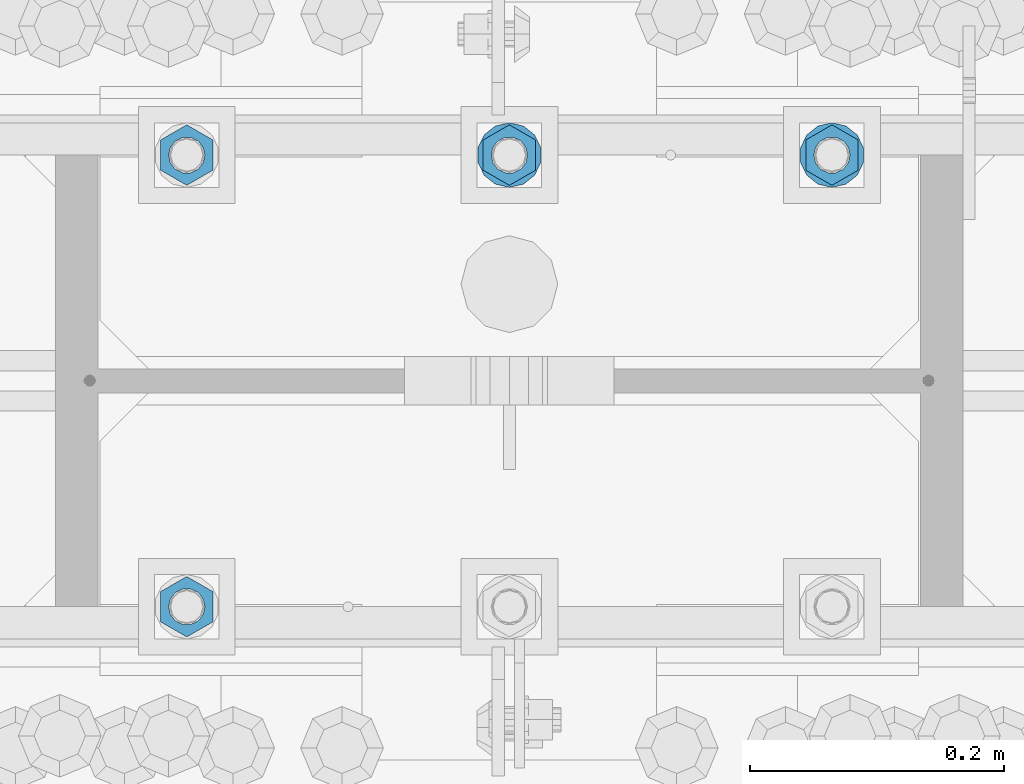
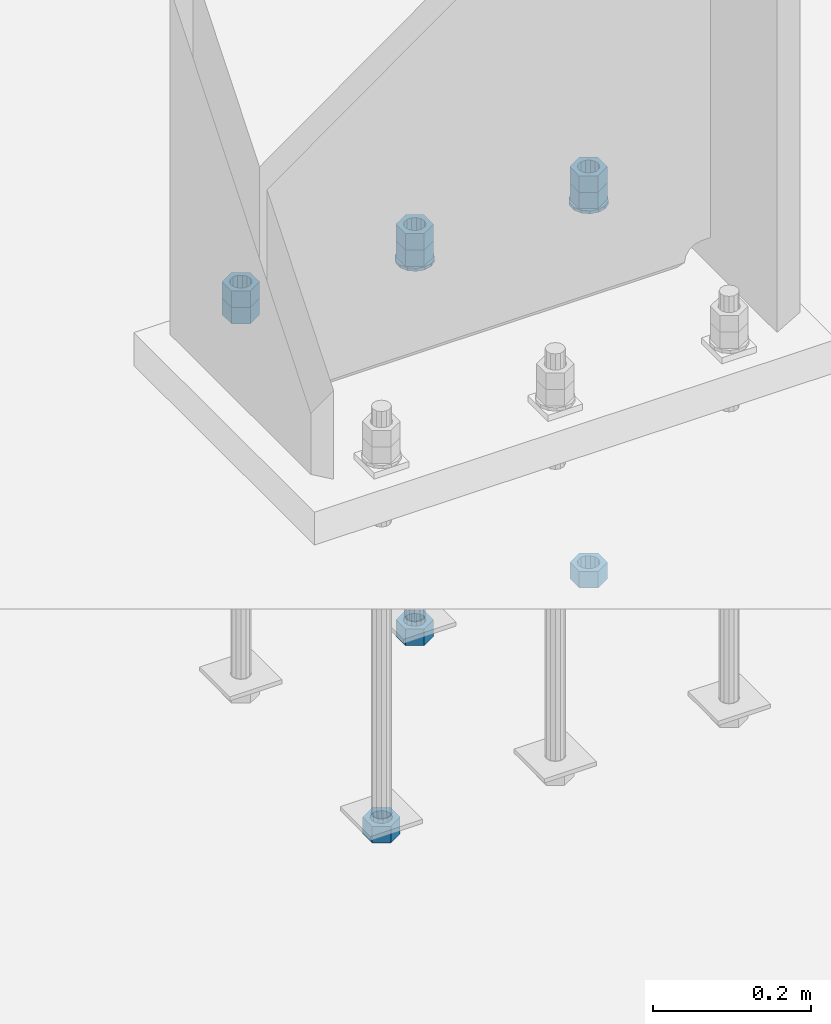
# One storey, part 1020 of 1763: 11 columns, 1 element without a shape of its own.
"""IFC2X3 building model written with IfcOpenShell, lengths in millimetres."""

from ifc_helpers import new_model, si_unit, frame, origin_with_axes, place, context, subcontext, project, spatial, faceted_brep, material, type_object, element, aggregate, save


model = new_model("IFC2X3")

# Units and contexts
model_context = context("Model", 3, precision=1e-05, world=origin_with_axes())
body_context = subcontext(model_context, "Body", "Model", "MODEL_VIEW")
ifc_project = project(units=[si_unit("LENGTHUNIT", "METRE", prefix="MILLI"), si_unit("AREAUNIT", "SQUARE_METRE"), si_unit("VOLUMEUNIT", "CUBIC_METRE"), si_unit("MASSUNIT", "GRAM", prefix="KILO"), si_unit("TIMEUNIT", "SECOND"), si_unit("PLANEANGLEUNIT", "RADIAN"), si_unit("SOLIDANGLEUNIT", "STERADIAN"), si_unit("THERMODYNAMICTEMPERATUREUNIT", "DEGREE_CELSIUS"), si_unit("LUMINOUSINTENSITYUNIT", "LUMEN")], contexts=[model_context])

# Site, building, storey
site_placement = place(None, origin_with_axes())
site = spatial("IfcSite", under=ifc_project, at=site_placement, CompositionType="ELEMENT")
building_placement = place(site_placement, origin_with_axes())
building = spatial("IfcBuilding", under=site, at=building_placement, Name="Undefined", CompositionType="ELEMENT")
storey_placement = place(building_placement, origin_with_axes())
storey = spatial("IfcBuildingStorey", under=building, at=storey_placement, Name="Undefined", CompositionType="ELEMENT", Elevation=0.0)

# Assembly, columns
assembly_placement = place(storey_placement, origin_with_axes())
assembly = element("IfcElementAssembly", 1, at=assembly_placement, inside=storey, Name="TEMPLATE", AssemblyPlace="NOTDEFINED", PredefinedType="RIGID_FRAME")
ifc_material_1 = material(Name="STEEL/A563")
column_type_1 = type_object("IfcColumnType", Name="1_HEAVY_HEX_NUT", PredefinedType="NOTDEFINED")
column_1_placement = place(assembly_placement, frame((-72237.0372736984, 52298.6, -150.812499999999), z_axis=(-1.0, 0.0, 0.0), x_axis=(0.0, 0.0, -1.0)))
column_1 = element("IfcColumn", 2, at=column_1_placement, type_object=column_type_1, material=ifc_material_1, Name="NUT", ObjectType="1_HEAVY_HEX_NUT", context=body_context, shape_type="Brep", body=[
    faceted_brep([(0.0, -23.8099994659424, 0.0), (0.0, -11.9099998474121, -20.6200008392334), (25.4, -11.9099998474121, -20.6200008392334), (25.4, -23.8099994659424, 0.0), (0.0, 11.9099998474121, -20.6200008392334), (25.4, 11.9099998474121, -20.6200008392334), (0.0, 23.8099994659424, 0.0), (25.4, 23.8099994659424, 0.0), (0.0, 11.9099998474121, 20.6200008392334), (25.4, 11.9099998474121, 20.6200008392334), (0.0, -11.9099998474121, 20.6200008392334), (25.4, -11.9099998474121, 20.6200008392334), (0.0, 0.0, 14.289999961853), (0.0, 6.20019861543551, 12.8748450879575), (25.4, 6.20019861543551, 12.8748450879502), (25.4, 0.0, 14.289999961853), (0.0, 11.1723718546418, 8.90966924477834), (25.4, 11.1723718546418, 8.90966924477834), (0.0, 13.9317198278877, 3.17982413774735), (25.4, 13.9317198278877, 3.17982413774007), (0.0, 13.9317198278877, -3.17982413774735), (25.4, 13.9317198278877, -3.17982413774007), (0.0, 11.1723718546418, -8.90966924477834), (25.4, 11.1723718546418, -8.90966924477834), (0.0, 6.20019861543551, -12.8748450879575), (25.4, 6.20019861543551, -12.8748450879502), (0.0, 0.0, -14.289999961853), (25.4, 0.0, -14.289999961853), (0.0, -6.20019861543551, -12.8748450879575), (25.4, -6.20019861543551, -12.8748450879502), (0.0, -11.1723718546418, -8.90966924477834), (25.4, -11.1723718546418, -8.90966924477834), (0.0, -13.9317198278877, -3.17982413774735), (25.4, -13.9317198278877, -3.17982413774007), (0.0, -13.9317198278877, 3.17982413774735), (25.4, -13.9317198278877, 3.17982413774007), (0.0, -11.1723718546418, 8.90966924477834), (25.4, -11.1723718546418, 8.90966924477834), (0.0, -6.20019861543551, 12.8748450879575), (25.4, -6.20019861543551, 12.8748450879502)], [[[0, 1, 2, 3]], [[1, 4, 5, 2]], [[4, 6, 7, 5]], [[6, 8, 9, 7]], [[8, 10, 11, 9]], [[10, 0, 3, 11]], [[12, 13, 14, 15]], [[13, 16, 17, 14]], [[16, 18, 19, 17]], [[18, 20, 21, 19]], [[20, 22, 23, 21]], [[22, 24, 25, 23]], [[24, 26, 27, 25]], [[26, 28, 29, 27]], [[28, 30, 31, 29]], [[30, 32, 33, 31]], [[32, 34, 35, 33]], [[34, 36, 37, 35]], [[36, 38, 39, 37]], [[38, 12, 15, 39]], [[5, 7, 9, 11, 3, 2], [17, 19, 21, 23, 25, 27, 29, 31, 33, 35, 37, 39, 15, 14]], [[10, 8, 6, 4, 1, 0], [38, 36, 34, 32, 30, 28, 26, 24, 22, 20, 18, 16, 13, 12]]]),
])
column_2_placement = place(assembly_placement, frame((-72491.0372736984, 52298.6, -150.812499999999), z_axis=(-1.0, 0.0, 0.0), x_axis=(0.0, 0.0, -1.0)))
column_2 = element("IfcColumn", 3, at=column_2_placement, type_object=column_type_1, material=ifc_material_1, Name="NUT", ObjectType="1_HEAVY_HEX_NUT", context=body_context, shape_type="Brep", body=[
    faceted_brep([(0.0, -23.8099994659424, 0.0), (0.0, -11.9099998474121, -20.6200008392334), (25.4, -11.9099998474121, -20.6200008392334), (25.4, -23.8099994659424, 0.0), (0.0, 11.9099998474121, -20.6200008392334), (25.4, 11.9099998474121, -20.6200008392334), (0.0, 23.8099994659424, 0.0), (25.4, 23.8099994659424, 0.0), (0.0, 11.9099998474121, 20.6200008392334), (25.4, 11.9099998474121, 20.6200008392334), (0.0, -11.9099998474121, 20.6200008392334), (25.4, -11.9099998474121, 20.6200008392334), (0.0, 0.0, 14.289999961853), (0.0, 6.20019861543551, 12.8748450879575), (25.4, 6.20019861543551, 12.8748450879502), (25.4, 0.0, 14.289999961853), (0.0, 11.1723718546418, 8.90966924477834), (25.4, 11.1723718546418, 8.90966924477834), (0.0, 13.9317198278877, 3.17982413774735), (25.4, 13.9317198278877, 3.17982413774007), (0.0, 13.9317198278877, -3.17982413774735), (25.4, 13.9317198278877, -3.17982413774007), (0.0, 11.1723718546418, -8.90966924477834), (25.4, 11.1723718546418, -8.90966924477834), (0.0, 6.20019861543551, -12.8748450879575), (25.4, 6.20019861543551, -12.8748450879502), (0.0, 0.0, -14.289999961853), (25.4, 0.0, -14.289999961853), (0.0, -6.20019861543551, -12.8748450879575), (25.4, -6.20019861543551, -12.8748450879502), (0.0, -11.1723718546418, -8.90966924477834), (25.4, -11.1723718546418, -8.90966924477834), (0.0, -13.9317198278877, -3.17982413774735), (25.4, -13.9317198278877, -3.17982413774007), (0.0, -13.9317198278877, 3.17982413774735), (25.4, -13.9317198278877, 3.17982413774007), (0.0, -11.1723718546418, 8.90966924477834), (25.4, -11.1723718546418, 8.90966924477834), (0.0, -6.20019861543551, 12.8748450879575), (25.4, -6.20019861543551, 12.8748450879502)], [[[0, 1, 2, 3]], [[1, 4, 5, 2]], [[4, 6, 7, 5]], [[6, 8, 9, 7]], [[8, 10, 11, 9]], [[10, 0, 3, 11]], [[12, 13, 14, 15]], [[13, 16, 17, 14]], [[16, 18, 19, 17]], [[18, 20, 21, 19]], [[20, 22, 23, 21]], [[22, 24, 25, 23]], [[24, 26, 27, 25]], [[26, 28, 29, 27]], [[28, 30, 31, 29]], [[30, 32, 33, 31]], [[32, 34, 35, 33]], [[34, 36, 37, 35]], [[36, 38, 39, 37]], [[38, 12, 15, 39]], [[5, 7, 9, 11, 3, 2], [17, 19, 21, 23, 25, 27, 29, 31, 33, 35, 37, 39, 15, 14]], [[10, 8, 6, 4, 1, 0], [38, 36, 34, 32, 30, 28, 26, 24, 22, 20, 18, 16, 13, 12]]]),
])
column_3_placement = place(assembly_placement, frame((-72745.0372736984, 52298.6, -150.812499999999), z_axis=(-1.0, 0.0, 0.0), x_axis=(0.0, 0.0, -1.0)))
column_3 = element("IfcColumn", 4, at=column_3_placement, type_object=column_type_1, material=ifc_material_1, Name="NUT", ObjectType="1_HEAVY_HEX_NUT", context=body_context, shape_type="Brep", body=[
    faceted_brep([(0.0, -23.8099994659424, 0.0), (0.0, -11.9099998474121, -20.6200008392334), (25.4, -11.9099998474121, -20.6200008392334), (25.4, -23.8099994659424, 0.0), (0.0, 11.9099998474121, -20.6200008392334), (25.4, 11.9099998474121, -20.6200008392334), (0.0, 23.8099994659424, 0.0), (25.4, 23.8099994659424, 0.0), (0.0, 11.9099998474121, 20.6200008392334), (25.4, 11.9099998474121, 20.6200008392334), (0.0, -11.9099998474121, 20.6200008392334), (25.4, -11.9099998474121, 20.6200008392334), (0.0, 0.0, 14.289999961853), (0.0, 6.20019861543551, 12.8748450879575), (25.4, 6.20019861543551, 12.8748450879502), (25.4, 0.0, 14.289999961853), (0.0, 11.1723718546418, 8.90966924477834), (25.4, 11.1723718546418, 8.90966924477834), (0.0, 13.9317198278877, 3.17982413774735), (25.4, 13.9317198278877, 3.17982413774007), (0.0, 13.9317198278877, -3.17982413774735), (25.4, 13.9317198278877, -3.17982413774007), (0.0, 11.1723718546418, -8.90966924477834), (25.4, 11.1723718546418, -8.90966924477834), (0.0, 6.20019861543551, -12.8748450879575), (25.4, 6.20019861543551, -12.8748450879502), (0.0, 0.0, -14.289999961853), (25.4, 0.0, -14.289999961853), (0.0, -6.20019861543551, -12.8748450879575), (25.4, -6.20019861543551, -12.8748450879502), (0.0, -11.1723718546418, -8.90966924477834), (25.4, -11.1723718546418, -8.90966924477834), (0.0, -13.9317198278877, -3.17982413774735), (25.4, -13.9317198278877, -3.17982413774007), (0.0, -13.9317198278877, 3.17982413774735), (25.4, -13.9317198278877, 3.17982413774007), (0.0, -11.1723718546418, 8.90966924477834), (25.4, -11.1723718546418, 8.90966924477834), (0.0, -6.20019861543551, 12.8748450879575), (25.4, -6.20019861543551, 12.8748450879502)], [[[0, 1, 2, 3]], [[1, 4, 5, 2]], [[4, 6, 7, 5]], [[6, 8, 9, 7]], [[8, 10, 11, 9]], [[10, 0, 3, 11]], [[12, 13, 14, 15]], [[13, 16, 17, 14]], [[16, 18, 19, 17]], [[18, 20, 21, 19]], [[20, 22, 23, 21]], [[22, 24, 25, 23]], [[24, 26, 27, 25]], [[26, 28, 29, 27]], [[28, 30, 31, 29]], [[30, 32, 33, 31]], [[32, 34, 35, 33]], [[34, 36, 37, 35]], [[36, 38, 39, 37]], [[38, 12, 15, 39]], [[5, 7, 9, 11, 3, 2], [17, 19, 21, 23, 25, 27, 29, 31, 33, 35, 37, 39, 15, 14]], [[10, 8, 6, 4, 1, 0], [38, 36, 34, 32, 30, 28, 26, 24, 22, 20, 18, 16, 13, 12]]]),
])
column_4_placement = place(assembly_placement, frame((-72237.0372736984, 52298.6, -176.212499999999), z_axis=(-1.0, 0.0, 0.0), x_axis=(0.0, 0.0, -1.0)))
column_4 = element("IfcColumn", 5, at=column_4_placement, type_object=column_type_1, material=ifc_material_1, Name="NUT", ObjectType="1_HEAVY_HEX_NUT", context=body_context, shape_type="Brep", body=[
    faceted_brep([(0.0, -23.8099994659424, 0.0), (0.0, -11.9099998474121, -20.6200008392334), (25.4, -11.9099998474121, -20.6200008392334), (25.4, -23.8099994659424, 0.0), (0.0, 11.9099998474121, -20.6200008392334), (25.4, 11.9099998474121, -20.6200008392334), (0.0, 23.8099994659424, 0.0), (25.4, 23.8099994659424, 0.0), (0.0, 11.9099998474121, 20.6200008392334), (25.4, 11.9099998474121, 20.6200008392334), (0.0, -11.9099998474121, 20.6200008392334), (25.4, -11.9099998474121, 20.6200008392334), (0.0, 0.0, 14.289999961853), (0.0, 6.20019861543551, 12.8748450879575), (25.4, 6.20019861543551, 12.8748450879502), (25.4, 0.0, 14.289999961853), (0.0, 11.1723718546418, 8.90966924477834), (25.4, 11.1723718546418, 8.90966924477834), (0.0, 13.9317198278877, 3.17982413774735), (25.4, 13.9317198278877, 3.17982413774007), (0.0, 13.9317198278877, -3.17982413774735), (25.4, 13.9317198278877, -3.17982413774007), (0.0, 11.1723718546418, -8.90966924477834), (25.4, 11.1723718546418, -8.90966924477834), (0.0, 6.20019861543551, -12.8748450879575), (25.4, 6.20019861543551, -12.8748450879502), (0.0, 0.0, -14.289999961853), (25.4, 0.0, -14.289999961853), (0.0, -6.20019861543551, -12.8748450879575), (25.4, -6.20019861543551, -12.8748450879502), (0.0, -11.1723718546418, -8.90966924477834), (25.4, -11.1723718546418, -8.90966924477834), (0.0, -13.9317198278877, -3.17982413774735), (25.4, -13.9317198278877, -3.17982413774007), (0.0, -13.9317198278877, 3.17982413774735), (25.4, -13.9317198278877, 3.17982413774007), (0.0, -11.1723718546418, 8.90966924477834), (25.4, -11.1723718546418, 8.90966924477834), (0.0, -6.20019861543551, 12.8748450879575), (25.4, -6.20019861543551, 12.8748450879502)], [[[0, 1, 2, 3]], [[1, 4, 5, 2]], [[4, 6, 7, 5]], [[6, 8, 9, 7]], [[8, 10, 11, 9]], [[10, 0, 3, 11]], [[12, 13, 14, 15]], [[13, 16, 17, 14]], [[16, 18, 19, 17]], [[18, 20, 21, 19]], [[20, 22, 23, 21]], [[22, 24, 25, 23]], [[24, 26, 27, 25]], [[26, 28, 29, 27]], [[28, 30, 31, 29]], [[30, 32, 33, 31]], [[32, 34, 35, 33]], [[34, 36, 37, 35]], [[36, 38, 39, 37]], [[38, 12, 15, 39]], [[5, 7, 9, 11, 3, 2], [17, 19, 21, 23, 25, 27, 29, 31, 33, 35, 37, 39, 15, 14]], [[10, 8, 6, 4, 1, 0], [38, 36, 34, 32, 30, 28, 26, 24, 22, 20, 18, 16, 13, 12]]]),
])
column_5_placement = place(assembly_placement, frame((-72237.0372736984, 52298.6, -761.999999999999), z_axis=(-1.0, 0.0, 0.0), x_axis=(0.0, 0.0, -1.0)))
column_5 = element("IfcColumn", 6, at=column_5_placement, type_object=column_type_1, material=ifc_material_1, Name="NUT", ObjectType="1_HEAVY_HEX_NUT", context=body_context, shape_type="Brep", body=[
    faceted_brep([(0.0, -23.8099994659424, 0.0), (0.0, -11.9099998474121, -20.6200008392334), (25.4, -11.9099998474121, -20.6200008392334), (25.4, -23.8099994659424, 0.0), (0.0, 11.9099998474121, -20.6200008392334), (25.4, 11.9099998474121, -20.6200008392334), (0.0, 23.8099994659424, 0.0), (25.4, 23.8099994659424, 0.0), (0.0, 11.9099998474121, 20.6200008392334), (25.4, 11.9099998474121, 20.6200008392334), (0.0, -11.9099998474121, 20.6200008392334), (25.4, -11.9099998474121, 20.6200008392334), (0.0, 0.0, 14.289999961853), (0.0, 6.20019861543551, 12.8748450879575), (25.4, 6.20019861543551, 12.8748450879502), (25.4, 0.0, 14.289999961853), (0.0, 11.1723718546418, 8.90966924477834), (25.4, 11.1723718546418, 8.90966924477834), (0.0, 13.9317198278877, 3.17982413774735), (25.4, 13.9317198278877, 3.17982413774007), (0.0, 13.9317198278877, -3.17982413774735), (25.4, 13.9317198278877, -3.17982413774007), (0.0, 11.1723718546418, -8.90966924477834), (25.4, 11.1723718546418, -8.90966924477834), (0.0, 6.20019861543551, -12.8748450879575), (25.4, 6.20019861543551, -12.8748450879502), (0.0, 0.0, -14.289999961853), (25.4, 0.0, -14.289999961853), (0.0, -6.20019861543551, -12.8748450879575), (25.4, -6.20019861543551, -12.8748450879502), (0.0, -11.1723718546418, -8.90966924477834), (25.4, -11.1723718546418, -8.90966924477834), (0.0, -13.9317198278877, -3.17982413774735), (25.4, -13.9317198278877, -3.17982413774007), (0.0, -13.9317198278877, 3.17982413774735), (25.4, -13.9317198278877, 3.17982413774007), (0.0, -11.1723718546418, 8.90966924477834), (25.4, -11.1723718546418, 8.90966924477834), (0.0, -6.20019861543551, 12.8748450879575), (25.4, -6.20019861543551, 12.8748450879502)], [[[0, 1, 2, 3]], [[1, 4, 5, 2]], [[4, 6, 7, 5]], [[6, 8, 9, 7]], [[8, 10, 11, 9]], [[10, 0, 3, 11]], [[12, 13, 14, 15]], [[13, 16, 17, 14]], [[16, 18, 19, 17]], [[18, 20, 21, 19]], [[20, 22, 23, 21]], [[22, 24, 25, 23]], [[24, 26, 27, 25]], [[26, 28, 29, 27]], [[28, 30, 31, 29]], [[30, 32, 33, 31]], [[32, 34, 35, 33]], [[34, 36, 37, 35]], [[36, 38, 39, 37]], [[38, 12, 15, 39]], [[5, 7, 9, 11, 3, 2], [17, 19, 21, 23, 25, 27, 29, 31, 33, 35, 37, 39, 15, 14]], [[10, 8, 6, 4, 1, 0], [38, 36, 34, 32, 30, 28, 26, 24, 22, 20, 18, 16, 13, 12]]]),
])
column_6_placement = place(assembly_placement, frame((-72491.0372736984, 52298.6, -176.212499999999), z_axis=(-1.0, 0.0, 0.0), x_axis=(0.0, 0.0, -1.0)))
column_6 = element("IfcColumn", 7, at=column_6_placement, type_object=column_type_1, material=ifc_material_1, Name="NUT", ObjectType="1_HEAVY_HEX_NUT", context=body_context, shape_type="Brep", body=[
    faceted_brep([(0.0, -23.8099994659424, 0.0), (0.0, -11.9099998474121, -20.6200008392334), (25.4, -11.9099998474121, -20.6200008392334), (25.4, -23.8099994659424, 0.0), (0.0, 11.9099998474121, -20.6200008392334), (25.4, 11.9099998474121, -20.6200008392334), (0.0, 23.8099994659424, 0.0), (25.4, 23.8099994659424, 0.0), (0.0, 11.9099998474121, 20.6200008392334), (25.4, 11.9099998474121, 20.6200008392334), (0.0, -11.9099998474121, 20.6200008392334), (25.4, -11.9099998474121, 20.6200008392334), (0.0, 0.0, 14.289999961853), (0.0, 6.20019861543551, 12.8748450879575), (25.4, 6.20019861543551, 12.8748450879502), (25.4, 0.0, 14.289999961853), (0.0, 11.1723718546418, 8.90966924477834), (25.4, 11.1723718546418, 8.90966924477834), (0.0, 13.9317198278877, 3.17982413774735), (25.4, 13.9317198278877, 3.17982413774007), (0.0, 13.9317198278877, -3.17982413774735), (25.4, 13.9317198278877, -3.17982413774007), (0.0, 11.1723718546418, -8.90966924477834), (25.4, 11.1723718546418, -8.90966924477834), (0.0, 6.20019861543551, -12.8748450879575), (25.4, 6.20019861543551, -12.8748450879502), (0.0, 0.0, -14.289999961853), (25.4, 0.0, -14.289999961853), (0.0, -6.20019861543551, -12.8748450879575), (25.4, -6.20019861543551, -12.8748450879502), (0.0, -11.1723718546418, -8.90966924477834), (25.4, -11.1723718546418, -8.90966924477834), (0.0, -13.9317198278877, -3.17982413774735), (25.4, -13.9317198278877, -3.17982413774007), (0.0, -13.9317198278877, 3.17982413774735), (25.4, -13.9317198278877, 3.17982413774007), (0.0, -11.1723718546418, 8.90966924477834), (25.4, -11.1723718546418, 8.90966924477834), (0.0, -6.20019861543551, 12.8748450879575), (25.4, -6.20019861543551, 12.8748450879502)], [[[0, 1, 2, 3]], [[1, 4, 5, 2]], [[4, 6, 7, 5]], [[6, 8, 9, 7]], [[8, 10, 11, 9]], [[10, 0, 3, 11]], [[12, 13, 14, 15]], [[13, 16, 17, 14]], [[16, 18, 19, 17]], [[18, 20, 21, 19]], [[20, 22, 23, 21]], [[22, 24, 25, 23]], [[24, 26, 27, 25]], [[26, 28, 29, 27]], [[28, 30, 31, 29]], [[30, 32, 33, 31]], [[32, 34, 35, 33]], [[34, 36, 37, 35]], [[36, 38, 39, 37]], [[38, 12, 15, 39]], [[5, 7, 9, 11, 3, 2], [17, 19, 21, 23, 25, 27, 29, 31, 33, 35, 37, 39, 15, 14]], [[10, 8, 6, 4, 1, 0], [38, 36, 34, 32, 30, 28, 26, 24, 22, 20, 18, 16, 13, 12]]]),
])
column_7_placement = place(assembly_placement, frame((-72491.0372736984, 52298.6, -761.999999999999), z_axis=(-1.0, 0.0, 0.0), x_axis=(0.0, 0.0, -1.0)))
column_7 = element("IfcColumn", 8, at=column_7_placement, type_object=column_type_1, material=ifc_material_1, Name="NUT", ObjectType="1_HEAVY_HEX_NUT", context=body_context, shape_type="Brep", body=[
    faceted_brep([(0.0, -23.8099994659424, 0.0), (0.0, -11.9099998474121, -20.6200008392334), (25.4, -11.9099998474121, -20.6200008392334), (25.4, -23.8099994659424, 0.0), (0.0, 11.9099998474121, -20.6200008392334), (25.4, 11.9099998474121, -20.6200008392334), (0.0, 23.8099994659424, 0.0), (25.4, 23.8099994659424, 0.0), (0.0, 11.9099998474121, 20.6200008392334), (25.4, 11.9099998474121, 20.6200008392334), (0.0, -11.9099998474121, 20.6200008392334), (25.4, -11.9099998474121, 20.6200008392334), (0.0, 0.0, 14.289999961853), (0.0, 6.20019861543551, 12.8748450879575), (25.4, 6.20019861543551, 12.8748450879502), (25.4, 0.0, 14.289999961853), (0.0, 11.1723718546418, 8.90966924477834), (25.4, 11.1723718546418, 8.90966924477834), (0.0, 13.9317198278877, 3.17982413774735), (25.4, 13.9317198278877, 3.17982413774007), (0.0, 13.9317198278877, -3.17982413774735), (25.4, 13.9317198278877, -3.17982413774007), (0.0, 11.1723718546418, -8.90966924477834), (25.4, 11.1723718546418, -8.90966924477834), (0.0, 6.20019861543551, -12.8748450879575), (25.4, 6.20019861543551, -12.8748450879502), (0.0, 0.0, -14.289999961853), (25.4, 0.0, -14.289999961853), (0.0, -6.20019861543551, -12.8748450879575), (25.4, -6.20019861543551, -12.8748450879502), (0.0, -11.1723718546418, -8.90966924477834), (25.4, -11.1723718546418, -8.90966924477834), (0.0, -13.9317198278877, -3.17982413774735), (25.4, -13.9317198278877, -3.17982413774007), (0.0, -13.9317198278877, 3.17982413774735), (25.4, -13.9317198278877, 3.17982413774007), (0.0, -11.1723718546418, 8.90966924477834), (25.4, -11.1723718546418, 8.90966924477834), (0.0, -6.20019861543551, 12.8748450879575), (25.4, -6.20019861543551, 12.8748450879502)], [[[0, 1, 2, 3]], [[1, 4, 5, 2]], [[4, 6, 7, 5]], [[6, 8, 9, 7]], [[8, 10, 11, 9]], [[10, 0, 3, 11]], [[12, 13, 14, 15]], [[13, 16, 17, 14]], [[16, 18, 19, 17]], [[18, 20, 21, 19]], [[20, 22, 23, 21]], [[22, 24, 25, 23]], [[24, 26, 27, 25]], [[26, 28, 29, 27]], [[28, 30, 31, 29]], [[30, 32, 33, 31]], [[32, 34, 35, 33]], [[34, 36, 37, 35]], [[36, 38, 39, 37]], [[38, 12, 15, 39]], [[5, 7, 9, 11, 3, 2], [17, 19, 21, 23, 25, 27, 29, 31, 33, 35, 37, 39, 15, 14]], [[10, 8, 6, 4, 1, 0], [38, 36, 34, 32, 30, 28, 26, 24, 22, 20, 18, 16, 13, 12]]]),
])
column_8_placement = place(assembly_placement, frame((-72745.0372736984, 51943.0, -761.999999999999), z_axis=(1.0, 0.0, 0.0), x_axis=(0.0, 0.0, -1.0)))
column_8 = element("IfcColumn", 9, at=column_8_placement, type_object=column_type_1, material=ifc_material_1, Name="NUT", ObjectType="1_HEAVY_HEX_NUT", context=body_context, shape_type="Brep", body=[
    faceted_brep([(0.0, -23.8099994659424, 0.0), (0.0, -11.9099998474121, -20.6200008392334), (25.4, -11.9099998474121, -20.6200008392334), (25.4, -23.8099994659424, 0.0), (0.0, 11.9099998474121, -20.6200008392334), (25.4, 11.9099998474121, -20.6200008392334), (0.0, 23.8099994659424, 0.0), (25.4, 23.8099994659424, 0.0), (0.0, 11.9099998474121, 20.6200008392334), (25.4, 11.9099998474121, 20.6200008392334), (0.0, -11.9099998474121, 20.6200008392334), (25.4, -11.9099998474121, 20.6200008392334), (0.0, 0.0, 14.289999961853), (0.0, 6.20019861543551, 12.8748450879575), (25.4, 6.20019861543551, 12.8748450879502), (25.4, 0.0, 14.289999961853), (0.0, 11.1723718546418, 8.90966924477834), (25.4, 11.1723718546418, 8.90966924477834), (0.0, 13.9317198278877, 3.17982413774735), (25.4, 13.9317198278877, 3.17982413774007), (0.0, 13.9317198278877, -3.17982413774735), (25.4, 13.9317198278877, -3.17982413774007), (0.0, 11.1723718546418, -8.90966924477834), (25.4, 11.1723718546418, -8.90966924477834), (0.0, 6.20019861543551, -12.8748450879575), (25.4, 6.20019861543551, -12.8748450879502), (0.0, 0.0, -14.289999961853), (25.4, 0.0, -14.289999961853), (0.0, -6.20019861543551, -12.8748450879575), (25.4, -6.20019861543551, -12.8748450879502), (0.0, -11.1723718546418, -8.90966924477834), (25.4, -11.1723718546418, -8.90966924477834), (0.0, -13.9317198278877, -3.17982413774735), (25.4, -13.9317198278877, -3.17982413774007), (0.0, -13.9317198278877, 3.17982413774735), (25.4, -13.9317198278877, 3.17982413774007), (0.0, -11.1723718546418, 8.90966924477834), (25.4, -11.1723718546418, 8.90966924477834), (0.0, -6.20019861543551, 12.8748450879575), (25.4, -6.20019861543551, 12.8748450879502)], [[[0, 1, 2, 3]], [[1, 4, 5, 2]], [[4, 6, 7, 5]], [[6, 8, 9, 7]], [[8, 10, 11, 9]], [[10, 0, 3, 11]], [[12, 13, 14, 15]], [[13, 16, 17, 14]], [[16, 18, 19, 17]], [[18, 20, 21, 19]], [[20, 22, 23, 21]], [[22, 24, 25, 23]], [[24, 26, 27, 25]], [[26, 28, 29, 27]], [[28, 30, 31, 29]], [[30, 32, 33, 31]], [[32, 34, 35, 33]], [[34, 36, 37, 35]], [[36, 38, 39, 37]], [[38, 12, 15, 39]], [[5, 7, 9, 11, 3, 2], [17, 19, 21, 23, 25, 27, 29, 31, 33, 35, 37, 39, 15, 14]], [[10, 8, 6, 4, 1, 0], [38, 36, 34, 32, 30, 28, 26, 24, 22, 20, 18, 16, 13, 12]]]),
])
column_9_placement = place(assembly_placement, frame((-72745.0372736984, 52298.6, -176.212499999999), z_axis=(-1.0, 0.0, 0.0), x_axis=(0.0, 0.0, -1.0)))
column_9 = element("IfcColumn", 10, at=column_9_placement, type_object=column_type_1, material=ifc_material_1, Name="NUT", ObjectType="1_HEAVY_HEX_NUT", context=body_context, shape_type="Brep", body=[
    faceted_brep([(0.0, -23.8099994659424, 0.0), (0.0, -11.9099998474121, -20.6200008392334), (25.4, -11.9099998474121, -20.6200008392334), (25.4, -23.8099994659424, 0.0), (0.0, 11.9099998474121, -20.6200008392334), (25.4, 11.9099998474121, -20.6200008392334), (0.0, 23.8099994659424, 0.0), (25.4, 23.8099994659424, 0.0), (0.0, 11.9099998474121, 20.6200008392334), (25.4, 11.9099998474121, 20.6200008392334), (0.0, -11.9099998474121, 20.6200008392334), (25.4, -11.9099998474121, 20.6200008392334), (0.0, 0.0, 14.289999961853), (0.0, 6.20019861543551, 12.8748450879575), (25.4, 6.20019861543551, 12.8748450879502), (25.4, 0.0, 14.289999961853), (0.0, 11.1723718546418, 8.90966924477834), (25.4, 11.1723718546418, 8.90966924477834), (0.0, 13.9317198278877, 3.17982413774735), (25.4, 13.9317198278877, 3.17982413774007), (0.0, 13.9317198278877, -3.17982413774735), (25.4, 13.9317198278877, -3.17982413774007), (0.0, 11.1723718546418, -8.90966924477834), (25.4, 11.1723718546418, -8.90966924477834), (0.0, 6.20019861543551, -12.8748450879575), (25.4, 6.20019861543551, -12.8748450879502), (0.0, 0.0, -14.289999961853), (25.4, 0.0, -14.289999961853), (0.0, -6.20019861543551, -12.8748450879575), (25.4, -6.20019861543551, -12.8748450879502), (0.0, -11.1723718546418, -8.90966924477834), (25.4, -11.1723718546418, -8.90966924477834), (0.0, -13.9317198278877, -3.17982413774735), (25.4, -13.9317198278877, -3.17982413774007), (0.0, -13.9317198278877, 3.17982413774735), (25.4, -13.9317198278877, 3.17982413774007), (0.0, -11.1723718546418, 8.90966924477834), (25.4, -11.1723718546418, 8.90966924477834), (0.0, -6.20019861543551, 12.8748450879575), (25.4, -6.20019861543551, 12.8748450879502)], [[[0, 1, 2, 3]], [[1, 4, 5, 2]], [[4, 6, 7, 5]], [[6, 8, 9, 7]], [[8, 10, 11, 9]], [[10, 0, 3, 11]], [[12, 13, 14, 15]], [[13, 16, 17, 14]], [[16, 18, 19, 17]], [[18, 20, 21, 19]], [[20, 22, 23, 21]], [[22, 24, 25, 23]], [[24, 26, 27, 25]], [[26, 28, 29, 27]], [[28, 30, 31, 29]], [[30, 32, 33, 31]], [[32, 34, 35, 33]], [[34, 36, 37, 35]], [[36, 38, 39, 37]], [[38, 12, 15, 39]], [[5, 7, 9, 11, 3, 2], [17, 19, 21, 23, 25, 27, 29, 31, 33, 35, 37, 39, 15, 14]], [[10, 8, 6, 4, 1, 0], [38, 36, 34, 32, 30, 28, 26, 24, 22, 20, 18, 16, 13, 12]]]),
])
ifc_material_2 = material(Name="STEEL/F436")
column_type_2 = type_object("IfcColumnType", Name="1_WASHER", PredefinedType="NOTDEFINED")
column_10_placement = place(assembly_placement, frame((-72237.0372736984, 52298.6, -201.612499999999), z_axis=(-1.0, 0.0, 0.0), x_axis=(0.0, 0.0, -1.0)))
column_10 = element("IfcColumn", 11, at=column_10_placement, type_object=column_type_2, material=ifc_material_2, Name="WASHER", ObjectType="1_WASHER", context=body_context, shape_type="Brep", body=[
    faceted_brep([(0.0, -25.4000000000015, 0.0), (0.0, -22.8846089010258, -11.0206468080723), (4.76249999999982, -22.8846089010258, -11.0206468080723), (4.76249999999982, -25.3999996185303, 0.0), (0.0, -15.8366407293724, -19.8585193564359), (4.76249999999982, -15.8366407293724, -19.8585193564359), (0.0, -5.65203163760452, -24.7631685975066), (4.76249999999982, -5.65203163760452, -24.7631685975066), (0.0, 5.65203163760452, -24.7631685975066), (4.76249999999982, 5.65203163760452, -24.7631685975066), (0.0, 15.8366407293724, -19.8585193564359), (4.76249999999982, 15.8366407293724, -19.8585193564359), (0.0, 22.8846089010258, -11.0206468080723), (4.76249999999982, 22.8846089010258, -11.0206468080723), (0.0, 25.4000000000015, 0.0), (4.76249999999982, 25.3999996185303, 0.0), (0.0, 22.8846089010258, 11.0206468080723), (4.76249999999982, 22.8846089010258, 11.0206468080723), (0.0, 15.8366407293724, 19.8585193564359), (4.76249999999982, 15.8366407293724, 19.8585193564359), (0.0, 5.65203163760452, 24.7631685975066), (4.76249999999982, 5.65203163760452, 24.7631685975066), (0.0, -5.65203163760452, 24.7631685975066), (4.76249999999982, -5.65203163760452, 24.7631685975066), (0.0, -15.8366407293724, 19.8585193564359), (4.76249999999982, -15.8366407293724, 19.8585193564359), (0.0, -22.8846089010258, 11.0206468080723), (4.76249999999982, -22.8846089010258, 11.0206468080723), (0.0, 0.0, 14.289999961853), (0.0, 6.20019861543551, 12.8748450879575), (4.76249999999982, 6.20019861543551, 12.8748450879502), (4.76249999999982, 0.0, 14.289999961853), (0.0, 11.1723718546418, 8.90966924477834), (4.76249999999982, 11.1723718546418, 8.90966924477834), (0.0, 13.9317198278877, 3.17982413774735), (4.76249999999982, 13.9317198278877, 3.17982413774007), (0.0, 13.9317198278877, -3.17982413774735), (4.76249999999982, 13.9317198278877, -3.17982413774007), (0.0, 11.1723718546418, -8.90966924477834), (4.76249999999982, 11.1723718546418, -8.90966924477834), (0.0, 6.20019861543551, -12.8748450879575), (4.76249999999982, 6.20019861543551, -12.8748450879502), (0.0, 0.0, -14.289999961853), (4.76249999999982, 0.0, -14.289999961853), (0.0, -6.20019861543551, -12.8748450879575), (4.76249999999982, -6.20019861543551, -12.8748450879502), (0.0, -11.1723718546418, -8.90966924477834), (4.76249999999982, -11.1723718546418, -8.90966924477834), (0.0, -13.9317198278877, -3.17982413774735), (4.76249999999982, -13.9317198278877, -3.17982413774007), (0.0, -13.9317198278877, 3.17982413774735), (4.76249999999982, -13.9317198278877, 3.17982413774007), (0.0, -11.1723718546418, 8.90966924477834), (4.76249999999982, -11.1723718546418, 8.90966924477834), (0.0, -6.20019861543551, 12.8748450879575), (4.76249999999982, -6.20019861543551, 12.8748450879502)], [[[0, 1, 2, 3]], [[1, 4, 5, 2]], [[4, 6, 7, 5]], [[6, 8, 9, 7]], [[8, 10, 11, 9]], [[10, 12, 13, 11]], [[12, 14, 15, 13]], [[14, 16, 17, 15]], [[16, 18, 19, 17]], [[18, 20, 21, 19]], [[20, 22, 23, 21]], [[22, 24, 25, 23]], [[24, 26, 27, 25]], [[26, 0, 3, 27]], [[28, 29, 30, 31]], [[29, 32, 33, 30]], [[32, 34, 35, 33]], [[34, 36, 37, 35]], [[36, 38, 39, 37]], [[38, 40, 41, 39]], [[40, 42, 43, 41]], [[42, 44, 45, 43]], [[44, 46, 47, 45]], [[46, 48, 49, 47]], [[48, 50, 51, 49]], [[50, 52, 53, 51]], [[52, 54, 55, 53]], [[54, 28, 31, 55]], [[5, 7, 9, 11, 13, 15, 17, 19, 21, 23, 25, 27, 3, 2], [33, 35, 37, 39, 41, 43, 45, 47, 49, 51, 53, 55, 31, 30]], [[26, 24, 22, 20, 18, 16, 14, 12, 10, 8, 6, 4, 1, 0], [54, 52, 50, 48, 46, 44, 42, 40, 38, 36, 34, 32, 29, 28]]]),
])
column_11_placement = place(assembly_placement, frame((-72491.0372736984, 52298.6, -201.612499999999), z_axis=(-1.0, 0.0, 0.0), x_axis=(0.0, 0.0, -1.0)))
column_11 = element("IfcColumn", 12, at=column_11_placement, type_object=column_type_2, material=ifc_material_2, Name="WASHER", ObjectType="1_WASHER", context=body_context, shape_type="Brep", body=[
    faceted_brep([(0.0, -25.4000000000015, 0.0), (0.0, -22.8846089010258, -11.0206468080723), (4.76249999999982, -22.8846089010258, -11.0206468080723), (4.76249999999982, -25.3999996185303, 0.0), (0.0, -15.8366407293724, -19.8585193564359), (4.76249999999982, -15.8366407293724, -19.8585193564359), (0.0, -5.65203163760452, -24.7631685975066), (4.76249999999982, -5.65203163760452, -24.7631685975066), (0.0, 5.65203163760452, -24.7631685975066), (4.76249999999982, 5.65203163760452, -24.7631685975066), (0.0, 15.8366407293724, -19.8585193564359), (4.76249999999982, 15.8366407293724, -19.8585193564359), (0.0, 22.8846089010258, -11.0206468080723), (4.76249999999982, 22.8846089010258, -11.0206468080723), (0.0, 25.4000000000015, 0.0), (4.76249999999982, 25.3999996185303, 0.0), (0.0, 22.8846089010258, 11.0206468080723), (4.76249999999982, 22.8846089010258, 11.0206468080723), (0.0, 15.8366407293724, 19.8585193564359), (4.76249999999982, 15.8366407293724, 19.8585193564359), (0.0, 5.65203163760452, 24.7631685975066), (4.76249999999982, 5.65203163760452, 24.7631685975066), (0.0, -5.65203163760452, 24.7631685975066), (4.76249999999982, -5.65203163760452, 24.7631685975066), (0.0, -15.8366407293724, 19.8585193564359), (4.76249999999982, -15.8366407293724, 19.8585193564359), (0.0, -22.8846089010258, 11.0206468080723), (4.76249999999982, -22.8846089010258, 11.0206468080723), (0.0, 0.0, 14.289999961853), (0.0, 6.20019861543551, 12.8748450879575), (4.76249999999982, 6.20019861543551, 12.8748450879502), (4.76249999999982, 0.0, 14.289999961853), (0.0, 11.1723718546418, 8.90966924477834), (4.76249999999982, 11.1723718546418, 8.90966924477834), (0.0, 13.9317198278877, 3.17982413774735), (4.76249999999982, 13.9317198278877, 3.17982413774007), (0.0, 13.9317198278877, -3.17982413774735), (4.76249999999982, 13.9317198278877, -3.17982413774007), (0.0, 11.1723718546418, -8.90966924477834), (4.76249999999982, 11.1723718546418, -8.90966924477834), (0.0, 6.20019861543551, -12.8748450879575), (4.76249999999982, 6.20019861543551, -12.8748450879502), (0.0, 0.0, -14.289999961853), (4.76249999999982, 0.0, -14.289999961853), (0.0, -6.20019861543551, -12.8748450879575), (4.76249999999982, -6.20019861543551, -12.8748450879502), (0.0, -11.1723718546418, -8.90966924477834), (4.76249999999982, -11.1723718546418, -8.90966924477834), (0.0, -13.9317198278877, -3.17982413774735), (4.76249999999982, -13.9317198278877, -3.17982413774007), (0.0, -13.9317198278877, 3.17982413774735), (4.76249999999982, -13.9317198278877, 3.17982413774007), (0.0, -11.1723718546418, 8.90966924477834), (4.76249999999982, -11.1723718546418, 8.90966924477834), (0.0, -6.20019861543551, 12.8748450879575), (4.76249999999982, -6.20019861543551, 12.8748450879502)], [[[0, 1, 2, 3]], [[1, 4, 5, 2]], [[4, 6, 7, 5]], [[6, 8, 9, 7]], [[8, 10, 11, 9]], [[10, 12, 13, 11]], [[12, 14, 15, 13]], [[14, 16, 17, 15]], [[16, 18, 19, 17]], [[18, 20, 21, 19]], [[20, 22, 23, 21]], [[22, 24, 25, 23]], [[24, 26, 27, 25]], [[26, 0, 3, 27]], [[28, 29, 30, 31]], [[29, 32, 33, 30]], [[32, 34, 35, 33]], [[34, 36, 37, 35]], [[36, 38, 39, 37]], [[38, 40, 41, 39]], [[40, 42, 43, 41]], [[42, 44, 45, 43]], [[44, 46, 47, 45]], [[46, 48, 49, 47]], [[48, 50, 51, 49]], [[50, 52, 53, 51]], [[52, 54, 55, 53]], [[54, 28, 31, 55]], [[5, 7, 9, 11, 13, 15, 17, 19, 21, 23, 25, 27, 3, 2], [33, 35, 37, 39, 41, 43, 45, 47, 49, 51, 53, 55, 31, 30]], [[26, 24, 22, 20, 18, 16, 14, 12, 10, 8, 6, 4, 1, 0], [54, 52, 50, 48, 46, 44, 42, 40, 38, 36, 34, 32, 29, 28]]]),
])
aggregate(assembly, [column_1, column_2, column_3, column_4, column_10, column_5, column_6, column_11, column_7, column_8, column_9])

save(model, "model.ifc")
